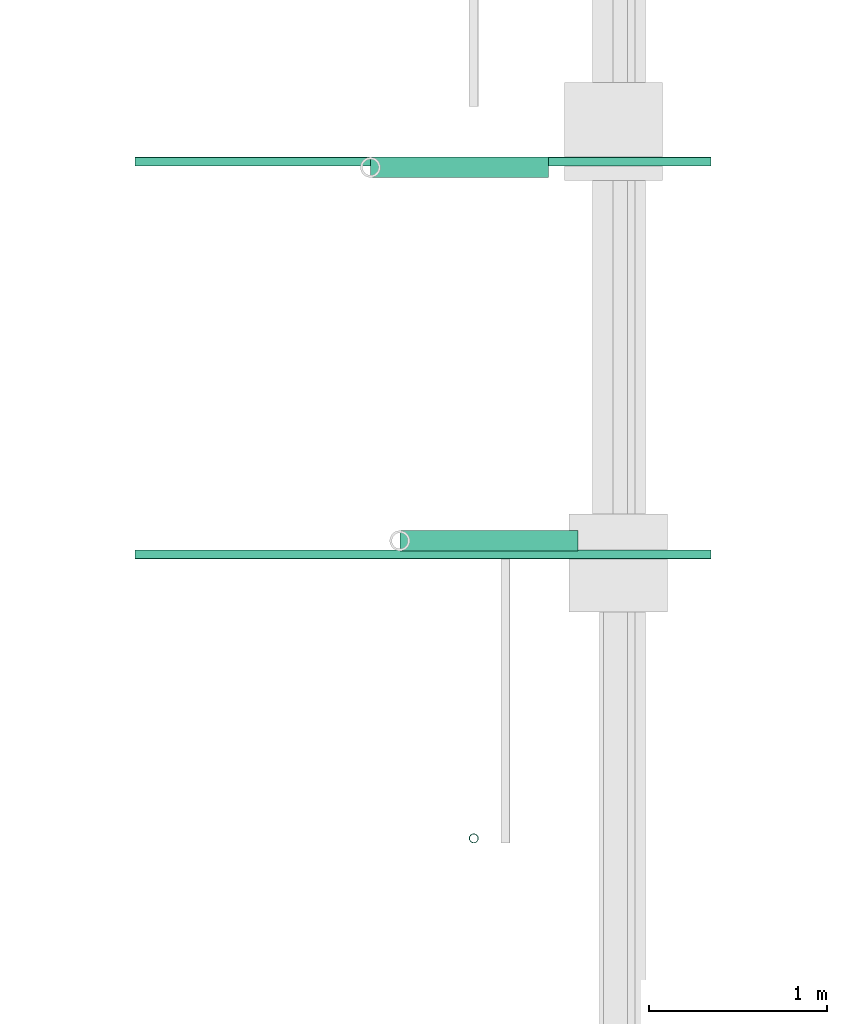
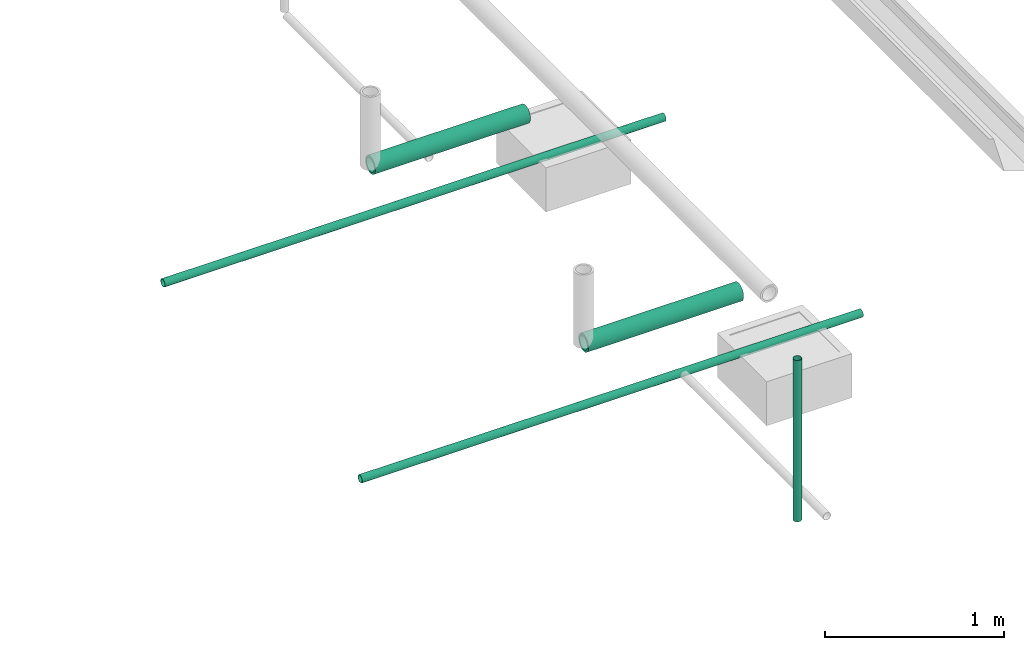
# One storey, part 3 of 15: 5 pipe segments.
"""IFC4X3_ADD2 building model written with IfcOpenShell, lengths in metres."""

from ifc_helpers import new_model, entity, si_unit, converted_unit, frame, origin_with_axes, origin_2d_with_axis, place, context, subcontext, project, spatial, hollow_circle, extrude, material, material_profile, profile_set, profile_usage, type_object, element, save


model = new_model("IFC4X3_ADD2")

# Units and contexts
model_context = context("Model", 3, precision=1e-05, world=origin_with_axes())
plan_context = context("Plan", 2, precision=1e-05, world=origin_2d_with_axis())
body_context = subcontext(model_context, "Body", "Model", "MODEL_VIEW")
ifc_project = project(units=[si_unit("VOLUMEUNIT", "CUBIC_METRE"), si_unit("LENGTHUNIT", "METRE"), converted_unit("PLANEANGLEUNIT", "degree", entity("IfcReal", 0.0174532925199433), si_unit("PLANEANGLEUNIT", "RADIAN"), dimensions=[0, 0, 0, 0, 0, 0, 0]), si_unit("AREAUNIT", "SQUARE_METRE")], contexts=[model_context, plan_context])

# Site, building, storey
site_placement = place(None, origin_with_axes())
site = spatial("IfcSite", under=ifc_project, at=site_placement)
building_placement = place(site_placement, origin_with_axes())
building = spatial("IfcBuilding", under=site, at=building_placement, Name="Building")
storey_placement = place(building_placement, origin_with_axes())
storey = spatial("IfcBuildingStorey", under=building, at=storey_placement, Name="Plumbing")

# Pipe segments
ifc_material_1 = material()
ifc_material_profile_1 = material_profile(ifc_material_1, hollow_circle(Radius=0.0571499988436699, WallThickness=0.012699999846518))
ifc_profile_set_1 = profile_set([ifc_material_profile_1])
ifc_profile_usage_1 = profile_usage(ifc_profile_set_1)
pipe_segment_type_1 = type_object("IfcPipeSegmentType", Name="4inch Tank", PredefinedType="FLEXIBLESEGMENT", material=ifc_profile_set_1)
pipe_segment_1_placement = place(storey_placement, frame((28.1763305664062, 17.7093620300293, 0.387610822916031), z_axis=(0.999999999999997, -1.19249099483909e-08, 7.54979012640431e-08), x_axis=(1.19248806385021e-08, 0.999999999999924, 3.89414395840474e-07)))
element("IfcPipeSegment", 1, at=pipe_segment_1_placement, inside=storey, type_object=pipe_segment_type_1, material=ifc_profile_usage_1, Name="PipeSegment", PredefinedType="FLEXIBLESEGMENT", context=body_context, shape_type="SweptSolid", body=[
    extrude(hollow_circle(Radius=0.0571499988436699, WallThickness=0.012699999846518), origin_with_axes(), (0.0, 0.0, 1.0), 1.0),
])
ifc_profile_usage_2 = profile_usage(ifc_profile_set_1)
pipe_segment_2_placement = place(storey_placement, frame((28.0115013122559, 19.8043346405029, 0.387610822916031), z_axis=(0.999999999999997, -1.19249099483909e-08, 7.54979012640431e-08), x_axis=(1.19248806385021e-08, 0.999999999999924, 3.89414395840474e-07)))
element("IfcPipeSegment", 2, at=pipe_segment_2_placement, inside=storey, type_object=pipe_segment_type_1, material=ifc_profile_usage_2, Name="PipeSegment", PredefinedType="FLEXIBLESEGMENT", context=body_context, shape_type="SweptSolid", body=[
    extrude(hollow_circle(Radius=0.0571499988436699, WallThickness=0.012699999846518), origin_with_axes(), (0.0, 0.0, 1.0), 1.0),
])
ifc_material_2 = material(Name="Wall")
ifc_material_profile_2 = material_profile(ifc_material_2, hollow_circle(Radius=0.0253999996930361, WallThickness=0.0020000000949949))
ifc_profile_set_2 = profile_set([ifc_material_profile_2])
ifc_profile_usage_3 = profile_usage(ifc_profile_set_2)
ifc_material_profile_3 = material_profile(ifc_material_2, hollow_circle(Radius=0.0253999996930361, WallThickness=0.0020000000949949))
ifc_profile_set_3 = profile_set([ifc_material_profile_3])
pipe_segment_type_2 = type_object("IfcPipeSegmentType", Name="2inch-bath outlet", PredefinedType="FLEXIBLESEGMENT", material=ifc_profile_set_3)
pipe_segment_3_placement = place(storey_placement, frame((28.5909576416016, 16.0401458740234, 0.0504299513995647), z_axis=(-8.74227481517655e-08, -1.19209317972489e-07, 0.999999999999989), x_axis=(-0.999999999999921, -3.89414367418763e-07, -8.7422797889751e-08)))
element("IfcPipeSegment", 3, at=pipe_segment_3_placement, inside=storey, type_object=pipe_segment_type_2, material=ifc_profile_usage_3, Name="PipeSegment", context=body_context, shape_type="SweptSolid", body=[
    extrude(hollow_circle(Radius=0.0253999996930361, WallThickness=0.0020000000949949), origin_with_axes(), (0.0, 0.0, 1.0), 1.09957002125543),
])
ifc_profile_usage_4 = profile_usage(ifc_profile_set_2)
pipe_segment_4_placement = place(storey_placement, frame((26.6916809082031, 17.633358001709, 0.0252150148153305), z_axis=(0.999999999999997, -1.19249099483909e-08, 7.54979012640431e-08), x_axis=(1.19248806385021e-08, 0.999999999999924, 3.89414395840474e-07)))
element("IfcPipeSegment", 4, at=pipe_segment_4_placement, inside=storey, type_object=pipe_segment_type_2, material=ifc_profile_usage_4, Name="PipeSegment", context=body_context, shape_type="SweptSolid", body=[
    extrude(hollow_circle(Radius=0.0253999996930361, WallThickness=0.0020000000949949), origin_with_axes(), (0.0, 0.0, 1.0), 3.2307224750629),
])
ifc_profile_usage_5 = profile_usage(ifc_profile_set_2)
pipe_segment_5_placement = place(storey_placement, frame((26.6916809082031, 19.8360843658447, 0.0252150148153305), z_axis=(0.999999999999997, -1.19249099483909e-08, 7.54979012640431e-08), x_axis=(1.19248806385021e-08, 0.999999999999924, 3.89414395840474e-07)))
element("IfcPipeSegment", 5, at=pipe_segment_5_placement, inside=storey, type_object=pipe_segment_type_2, material=ifc_profile_usage_5, Name="PipeSegment", context=body_context, shape_type="SweptSolid", body=[
    extrude(hollow_circle(Radius=0.0253999996930361, WallThickness=0.0020000000949949), origin_with_axes(), (0.0, 0.0, 1.0), 3.2307224750629),
])

save(model, "model.ifc")
